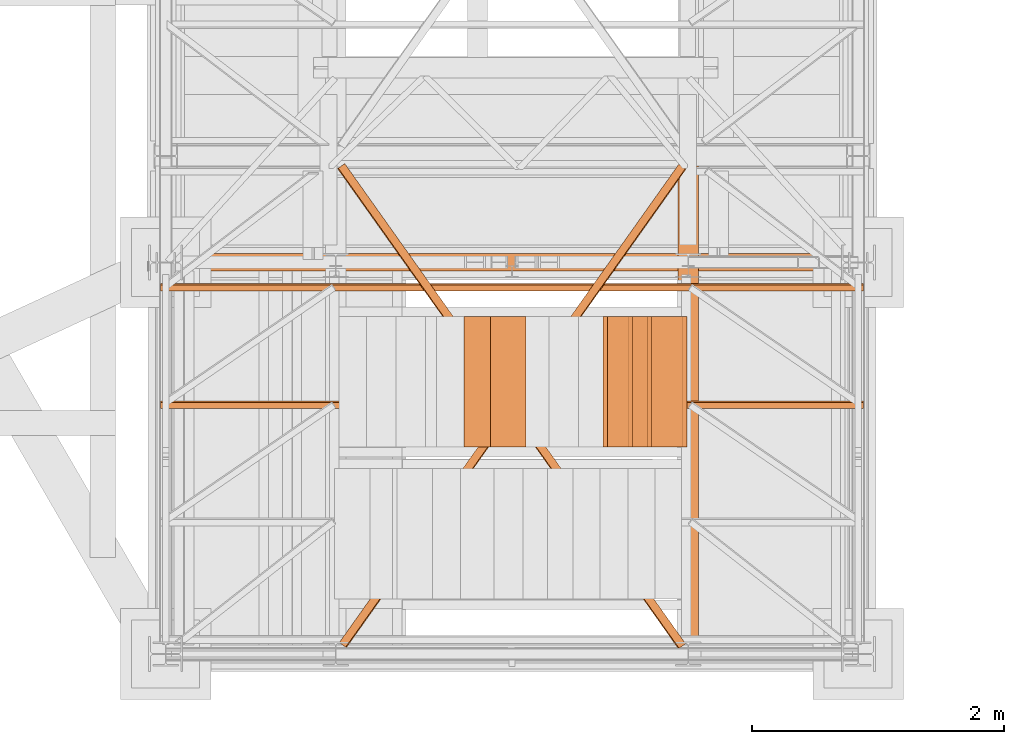
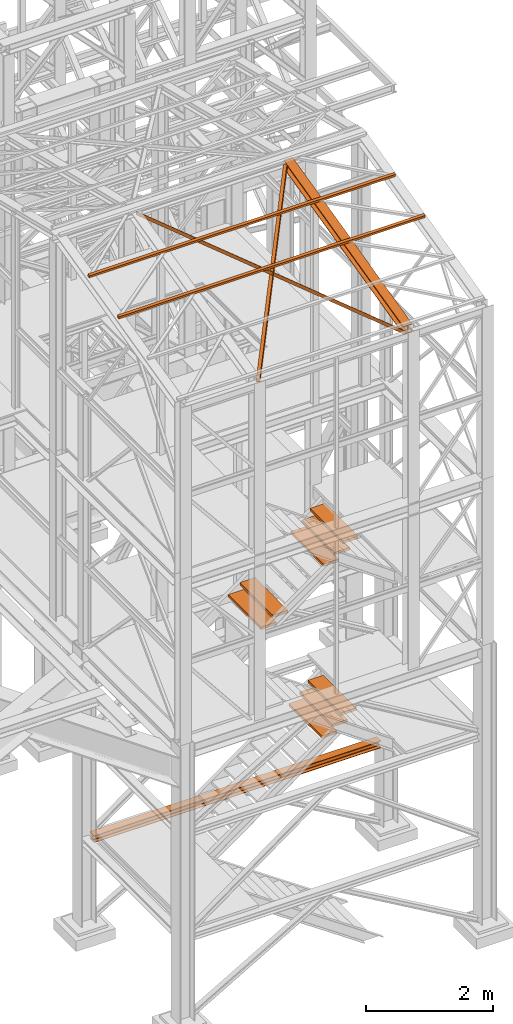
# One storey, part 53 of 208: 14 proxies.
"""IFC2X3 building model written with IfcOpenShell, lengths in millimetres."""

from ifc_helpers import new_model, entity, si_unit, converted_unit, frame, origin, origin_with_axes, place, context, subcontext, project, spatial, faceted_brep, element, save


model = new_model("IFC2X3")

# Units and contexts
model_context = context("Model", 3, precision=1e-05, world=origin())
plan_context = context("Plan", 3, precision=1e-05, world=origin())
body_context = subcontext(model_context, "Body", "Model", "MODEL_VIEW")
ifc_project = project(units=[si_unit("LENGTHUNIT", "METRE", prefix="MILLI"), converted_unit("PLANEANGLEUNIT", "DEGREE", entity("IfcPlaneAngleMeasure", 0.0174532925199433), si_unit("PLANEANGLEUNIT", "RADIAN"), dimensions=[0, 0, 0, 0, 0, 0, 0]), si_unit("AREAUNIT", "SQUARE_METRE"), si_unit("VOLUMEUNIT", "CUBIC_METRE")], contexts=[model_context, plan_context])

# Building, storey
building_placement = place(None, origin())
building = spatial("IfcBuilding", under=ifc_project, at=building_placement, CompositionType="COMPLEX")
storey_placement = place(building_placement, origin_with_axes())
storey = spatial("IfcBuildingStorey", under=building, at=storey_placement, Name="Geschoss", CompositionType="ELEMENT")

# Proxies
proxy_1_placement = place(storey_placement, frame((1333.254973893081, -22132.57439061591, 1433.489998909946), z_axis=(0.0, 0.0, 1.0), x_axis=(1.0, 0.0, 0.0)))
element("IfcBuildingElementProxy", 1, at=proxy_1_placement, inside=storey, context=body_context, shape_type="Brep", body=[
    faceted_brep([(0.01000000000021828, 0.01000000000567525, 8.510002324581137), (0.01000000000021828, 0.01000000000567525, 0.009999999999990905), (0.01000000000021828, 140.0100005960521, 0.009999999999990905), (0.01000000000021828, 140.0100005960521, 8.510002324581137), (0.01000000000021828, 84.76000038743587, 8.510002324581137), (0.01000000000021828, 78.54945996612878, 9.753034839630118), (0.01000000000021828, 74.00303279817672, 14.2994648015499), (0.01000000000021828, 72.76000051595838, 20.51000429153442), (0.01000000000021828, 72.76000051595838, 112.5100007450581), (0.01000000000021828, 74.00303279817672, 118.7205402350426), (0.01000000000021828, 78.54945996612878, 123.2669664716721), (0.01000000000021828, 84.76000038743587, 124.509998986721), (0.01000000000021828, 140.0100005960521, 124.509998986721), (0.01000000000021828, 140.0100005960521, 133.0100013113022), (0.01000000000021828, 0.01000000000567525, 133.0100013113022), (0.01000000000021828, 0.01000000000567525, 124.509998986721), (0.01000000000021828, 55.26000020862193, 124.509998986721), (0.01000000000021828, 61.47054062992902, 123.2669664716721), (0.01000000000021828, 66.01696779788108, 118.7205402350426), (0.01000000000021828, 67.26000008009942, 112.5100007450581), (0.01000000000021828, 67.26000008009942, 20.51000429153442), (0.01000000000021828, 66.01696779788108, 14.2994648015499), (0.01000000000021828, 61.47054062992902, 9.753034839630118), (0.01000000000021828, 55.26000020862193, 8.510002324581137), (0.01000000000021828, 0.01000000000567525, 0.009999999999990905), (0.01000000000021828, 0.01000000000567525, 8.510002324581137), (5230.009989271167, 0.01000000000203727, 8.510002324581137), (5230.009989271167, 0.01000000000203727, 0.009999999999990905), (0.01000000000021828, 140.0100005960521, 0.009999999999990905), (0.01000000000021828, 0.01000000000567525, 0.009999999999990905), (5230.009989271167, 0.01000000000203727, 0.009999999999990905), (5230.009989271167, 140.0100005960485, 0.009999999999990905), (0.01000000000021828, 140.0100005960521, 8.510002324581137), (0.01000000000021828, 140.0100005960521, 0.009999999999990905), (5230.009989271167, 140.0100005960485, 0.009999999999990905), (5230.009989271167, 140.0100005960485, 8.510002324581137), (0.01000000000021828, 84.76000038743587, 8.510002324581137), (0.01000000000021828, 140.0100005960521, 8.510002324581137), (5230.009989271167, 140.0100005960485, 8.510002324581137), (5230.009989271167, 84.76000038743223, 8.510002324581137), (0.01000000000021828, 78.54945996612878, 9.753034839630118), (0.01000000000021828, 84.76000038743587, 8.510002324581137), (5230.009989271167, 84.76000038743223, 8.510002324581137), (5230.009989271167, 78.54945996612514, 9.753034839630118), (0.01000000000021828, 74.00303279817672, 14.2994648015499), (0.01000000000021828, 78.54945996612878, 9.753034839630118), (5230.009989271167, 78.54945996612514, 9.753034839630118), (5230.009989271167, 74.00303279817308, 14.2994648015499), (0.01000000000021828, 72.76000051595838, 20.51000429153442), (0.01000000000021828, 74.00303279817672, 14.2994648015499), (5230.009989271167, 74.00303279817308, 14.2994648015499), (5230.009989271167, 72.76000051595474, 20.51000429153442), (0.01000000000021828, 72.76000051595838, 112.5100007450581), (0.01000000000021828, 72.76000051595838, 20.51000429153442), (5230.009989271167, 72.76000051595474, 20.51000429153442), (5230.009989271167, 72.76000051595474, 112.5100007450581), (0.01000000000021828, 74.00303279817672, 118.7205402350426), (0.01000000000021828, 72.76000051595838, 112.5100007450581), (5230.009989271167, 72.76000051595474, 112.5100007450581), (5230.009989271167, 74.00303279817308, 118.7205402350426), (0.01000000000021828, 78.54945996612878, 123.2669664716721), (0.01000000000021828, 74.00303279817672, 118.7205402350426), (5230.009989271167, 74.00303279817308, 118.7205402350426), (5230.009989271167, 78.54945996612514, 123.2669664716721), (0.01000000000021828, 84.76000038743587, 124.509998986721), (0.01000000000021828, 78.54945996612878, 123.2669664716721), (5230.009989271167, 78.54945996612514, 123.2669664716721), (5230.009989271167, 84.76000038743223, 124.509998986721), (0.01000000000021828, 140.0100005960521, 124.509998986721), (0.01000000000021828, 84.76000038743587, 124.509998986721), (5230.009989271167, 84.76000038743223, 124.509998986721), (5230.009989271167, 140.0100005960485, 124.509998986721), (0.01000000000021828, 140.0100005960521, 133.0100013113022), (0.01000000000021828, 140.0100005960521, 124.509998986721), (5230.009989271167, 140.0100005960485, 124.509998986721), (5230.009989271167, 140.0100005960485, 133.0100013113022), (0.01000000000021828, 0.01000000000567525, 133.0100013113022), (0.01000000000021828, 140.0100005960521, 133.0100013113022), (5230.009989271167, 140.0100005960485, 133.0100013113022), (5230.009989271167, 0.01000000000203727, 133.0100013113022), (0.01000000000021828, 0.01000000000567525, 124.509998986721), (0.01000000000021828, 0.01000000000567525, 133.0100013113022), (5230.009989271167, 0.01000000000203727, 133.0100013113022), (5230.009989271167, 0.01000000000203727, 124.509998986721), (0.01000000000021828, 55.26000020862193, 124.509998986721), (0.01000000000021828, 0.01000000000567525, 124.509998986721), (5230.009989271167, 0.01000000000203727, 124.509998986721), (5230.009989271167, 55.26000020861829, 124.509998986721), (0.01000000000021828, 61.47054062992902, 123.2669664716721), (0.01000000000021828, 55.26000020862193, 124.509998986721), (5230.009989271167, 55.26000020861829, 124.509998986721), (5230.009989271167, 61.47054062992538, 123.2669664716721), (0.01000000000021828, 66.01696779788108, 118.7205402350426), (0.01000000000021828, 61.47054062992902, 123.2669664716721), (5230.009989271167, 61.47054062992538, 123.2669664716721), (5230.009989271167, 66.01696779787744, 118.7205402350426), (0.01000000000021828, 67.26000008009942, 112.5100007450581), (0.01000000000021828, 66.01696779788108, 118.7205402350426), (5230.009989271167, 66.01696779787744, 118.7205402350426), (5230.009989271167, 67.26000008009578, 112.5100007450581), (0.01000000000021828, 67.26000008009942, 20.51000429153442), (0.01000000000021828, 67.26000008009942, 112.5100007450581), (5230.009989271167, 67.26000008009578, 112.5100007450581), (5230.009989271167, 67.26000008009578, 20.51000429153442), (0.01000000000021828, 66.01696779788108, 14.2994648015499), (0.01000000000021828, 67.26000008009942, 20.51000429153442), (5230.009989271167, 67.26000008009578, 20.51000429153442), (5230.009989271167, 66.01696779787744, 14.2994648015499), (0.01000000000021828, 61.47054062992902, 9.753034839630118), (0.01000000000021828, 66.01696779788108, 14.2994648015499), (5230.009989271167, 66.01696779787744, 14.2994648015499), (5230.009989271167, 61.47054062992538, 9.753034839630118), (0.01000000000021828, 55.26000020862193, 8.510002324581137), (0.01000000000021828, 61.47054062992902, 9.753034839630118), (5230.009989271167, 61.47054062992538, 9.753034839630118), (5230.009989271167, 55.26000020861829, 8.510002324581137), (0.01000000000021828, 0.01000000000567525, 8.510002324581137), (0.01000000000021828, 55.26000020862193, 8.510002324581137), (5230.009989271167, 55.26000020861829, 8.510002324581137), (5230.009989271167, 0.01000000000203727, 8.510002324581137), (5230.009989271167, 0.01000000000203727, 8.510002324581137), (5230.009989271167, 55.26000020861829, 8.510002324581137), (5230.009989271167, 61.47054062992538, 9.753034839630118), (5230.009989271167, 66.01696779787744, 14.2994648015499), (5230.009989271167, 67.26000008009578, 20.51000429153442), (5230.009989271167, 67.26000008009578, 112.5100007450581), (5230.009989271167, 66.01696779787744, 118.7205402350426), (5230.009989271167, 61.47054062992538, 123.2669664716721), (5230.009989271167, 55.26000020861829, 124.509998986721), (5230.009989271167, 0.01000000000203727, 124.509998986721), (5230.009989271167, 0.01000000000203727, 133.0100013113022), (5230.009989271167, 140.0100005960485, 133.0100013113022), (5230.009989271167, 140.0100005960485, 124.509998986721), (5230.009989271167, 84.76000038743223, 124.509998986721), (5230.009989271167, 78.54945996612514, 123.2669664716721), (5230.009989271167, 74.00303279817308, 118.7205402350426), (5230.009989271167, 72.76000051595474, 112.5100007450581), (5230.009989271167, 72.76000051595474, 20.51000429153442), (5230.009989271167, 74.00303279817308, 14.2994648015499), (5230.009989271167, 78.54945996612514, 9.753034839630118), (5230.009989271167, 84.76000038743223, 8.510002324581137), (5230.009989271167, 140.0100005960485, 8.510002324581137), (5230.009989271167, 140.0100005960485, 0.009999999999990905), (5230.009989271167, 0.01000000000203727, 0.009999999999990905)], [[[0, 1, 2, 3, 4, 5, 6, 7, 8, 9, 10, 11, 12, 13, 14, 15, 16, 17, 18, 19, 20, 21, 22, 23]], [[24, 25, 26, 27]], [[28, 29, 30, 31]], [[32, 33, 34, 35]], [[36, 37, 38, 39]], [[40, 41, 42, 43]], [[44, 45, 46, 47]], [[48, 49, 50, 51]], [[52, 53, 54, 55]], [[56, 57, 58, 59]], [[60, 61, 62, 63]], [[64, 65, 66, 67]], [[68, 69, 70, 71]], [[72, 73, 74, 75]], [[76, 77, 78, 79]], [[80, 81, 82, 83]], [[84, 85, 86, 87]], [[88, 89, 90, 91]], [[92, 93, 94, 95]], [[96, 97, 98, 99]], [[100, 101, 102, 103]], [[104, 105, 106, 107]], [[108, 109, 110, 111]], [[112, 113, 114, 115]], [[116, 117, 118, 119]], [[120, 121, 122, 123, 124, 125, 126, 127, 128, 129, 130, 131, 132, 133, 134, 135, 136, 137, 138, 139, 140, 141, 142, 143]]], orient=[[False], [False], [False], [False], [False], [False], [False], [False], [False], [False], [False], [False], [False], [False], [False], [False], [False], [False], [False], [False], [False], [False], [False], [False], [False], [False]]),
])
for number, where, z_axis, x_axis in (
    (2, (5022.476720343071, -23530.42800187884, 3443.990001490116), (0.0, 0.0, 1.0), (1.0, 0.0, 0.0)),
    (3, (4868.598750456611, -23530.42800187884, 3273.990001490115), (0.0, 0.0, 1.0), (1.0, 0.0, 0.0)),
    (4, (4671.437715496153, -23530.42800187884, 3121.502140765801), (0.0, 0.0, 1.0), (1.0, 0.0, 0.0)),
    (5, (5057.476720343067, -23530.42800187884, 6743.049952225937), (0.0, 0.0, 1.0), (1.0, 0.0, 0.0)),
    (6, (4903.598750456609, -23530.42800187884, 6573.049952225936), (0.0, 0.0, 1.0), (1.0, 0.0, 0.0)),
    (7, (4706.437715496153, -23530.42800187884, 6420.562091501623), (0.0, 0.0, 1.0), (1.0, 0.0, 0.0)),
):
    element("IfcBuildingElementProxy", number, at=place(storey_placement, frame(where, z_axis=z_axis, x_axis=x_axis)), inside=storey, context=body_context, shape_type="Brep", body=[
        faceted_brep([(0.009999999999308784, 0.00999999999839929, 0.01000000000021828), (280.2746556316179, 0.00999999999839929, 0.01000000000021828), (280.2746556316179, 1037.717170711916, 0.01000000000021828), (0.009999999999308784, 1037.717170711916, 0.01000000000021828), (280.2746556316179, 0.00999999999839929, 50.01000000000022), (0.009999999999308784, 0.00999999999839929, 50.01000000000022), (0.009999999999308784, 1037.717170711916, 50.01000000000022), (280.2746556316179, 1037.717170711916, 50.01000000000022), (280.2746556316179, 0.00999999999839929, 0.01000000000021828), (0.009999999999308784, 0.00999999999839929, 0.01000000000021828), (0.009999999999308784, 0.00999999999839929, 50.01000000000022), (280.2746556316179, 0.00999999999839929, 50.01000000000022), (280.2746556316179, 1037.717170711916, 0.01000000000021828), (280.2746556316179, 0.00999999999839929, 0.01000000000021828), (280.2746556316179, 0.00999999999839929, 50.01000000000022), (280.2746556316179, 1037.717170711916, 50.01000000000022), (0.009999999999308784, 1037.717170711916, 0.01000000000021828), (280.2746556316179, 1037.717170711916, 0.01000000000021828), (280.2746556316179, 1037.717170711916, 50.01000000000022), (0.009999999999308784, 1037.717170711916, 50.01000000000022), (0.009999999999308784, 0.00999999999839929, 0.01000000000021828), (0.009999999999308784, 1037.717170711916, 0.01000000000021828), (0.009999999999308784, 1037.717170711916, 50.01000000000022), (0.009999999999308784, 0.00999999999839929, 50.01000000000022)], [[[0, 1, 2, 3]], [[4, 5, 6, 7]], [[8, 9, 10, 11]], [[12, 13, 14, 15]], [[16, 17, 18, 19]], [[20, 21, 22, 23]]], orient=[[False], [False], [False], [False], [False], [False]]),
    ])
for number, where, z_axis, x_axis in (
    (8, (3565.974818265505, -23530.42800187884, 5605.165709983303), (0.0, 0.0, 1.0), (1.0, 0.0, 0.0)),
    (9, (3778.68549890098, -23530.42800187884, 5760.656955432321), (0.0, 0.0, 1.0), (1.0, 0.0, 0.0)),
):
    element("IfcBuildingElementProxy", number, at=place(storey_placement, frame(where, z_axis=z_axis, x_axis=x_axis)), inside=storey, context=body_context, shape_type="Brep", body=[
        faceted_brep([(0.01000000000021828, 0.00999999999839929, 0.01000000000021828), (280.2746556316183, 0.00999999999839929, 0.01000000000021828), (280.2746556316183, 1037.717170711916, 0.01000000000021828), (0.01000000000021828, 1037.717170711916, 0.01000000000021828), (280.2746556316183, 0.00999999999839929, 50.01000000000022), (0.01000000000021828, 0.00999999999839929, 50.01000000000022), (0.01000000000021828, 1037.717170711916, 50.01000000000022), (280.2746556316183, 1037.717170711916, 50.01000000000022), (280.2746556316183, 0.00999999999839929, 0.01000000000021828), (0.01000000000021828, 0.00999999999839929, 0.01000000000021828), (0.01000000000021828, 0.00999999999839929, 50.01000000000022), (280.2746556316183, 0.00999999999839929, 50.01000000000022), (280.2746556316183, 1037.717170711916, 0.01000000000021828), (280.2746556316183, 0.00999999999839929, 0.01000000000021828), (280.2746556316183, 0.00999999999839929, 50.01000000000022), (280.2746556316183, 1037.717170711916, 50.01000000000022), (0.01000000000021828, 1037.717170711916, 0.01000000000021828), (280.2746556316183, 1037.717170711916, 0.01000000000021828), (280.2746556316183, 1037.717170711916, 50.01000000000022), (0.01000000000021828, 1037.717170711916, 50.01000000000022), (0.01000000000021828, 0.00999999999839929, 0.01000000000021828), (0.01000000000021828, 1037.717170711916, 0.01000000000021828), (0.01000000000021828, 1037.717170711916, 50.01000000000022), (0.01000000000021828, 0.00999999999839929, 50.01000000000022)], [[[0, 1, 2, 3]], [[4, 5, 6, 7]], [[8, 9, 10, 11]], [[12, 13, 14, 15]], [[16, 17, 18, 19]], [[20, 21, 22, 23]]], orient=[[False], [False], [False], [False], [False], [False]]),
    ])
for number, where, z_axis, x_axis in (
    (10, (1157.254971121462, -22289.5100179109, 12464.98408158565), (0.0, 0.0, 1.0), (1.0, 0.0, 0.0)),
    (11, (1157.254971121462, -23222.63202388408, 12238.48670466169), (0.0, 0.0, 1.0), (1.0, 0.0, 0.0)),
):
    element("IfcBuildingElementProxy", number, at=place(storey_placement, frame(where, z_axis=z_axis, x_axis=x_axis)), inside=storey, context=body_context, shape_type="Brep", body=[
        faceted_brep([(5582.010002264974, 48.59909357395372, 60.39315927079588), (5582.010002264974, 60.39315927079224, 11.80406569683873), (5582.010002264974, 11.80406569683692, 0.01000000000021828), (5582.010002264974, 0.00999999999839929, 48.59909357395736), (0.01000000000021828, 0.00999999999839929, 48.59909357395736), (0.01000000000021828, 11.80406569683692, 0.01000000000021828), (0.01000000000021828, 60.39315927079224, 11.80406569683873), (0.01000000000021828, 48.59909357395372, 60.39315927079588), (5582.010002264974, 0.00999999999839929, 48.59909357395736), (0.01000000000021828, 0.00999999999839929, 48.59909357395736), (0.01000000000021828, 48.59909357395372, 60.39315927079588), (5582.010002264974, 48.59909357395372, 60.39315927079588), (5582.010002264974, 11.80406569683692, 0.01000000000021828), (0.01000000000021828, 11.80406569683692, 0.01000000000021828), (0.01000000000021828, 0.00999999999839929, 48.59909357395736), (5582.010002264974, 0.00999999999839929, 48.59909357395736), (5582.010002264974, 60.39315927079224, 11.80406569683873), (0.01000000000021828, 60.39315927079224, 11.80406569683873), (0.01000000000021828, 11.80406569683692, 0.01000000000021828), (5582.010002264974, 11.80406569683692, 0.01000000000021828), (5582.010002264974, 48.59909357395372, 60.39315927079588), (0.01000000000021828, 48.59909357395372, 60.39315927079588), (0.01000000000021828, 60.39315927079224, 11.80406569683873), (5582.010002264974, 60.39315927079224, 11.80406569683873)], [[[0, 1, 2, 3]], [[4, 5, 6, 7]], [[8, 9, 10, 11]], [[12, 13, 14, 15]], [[16, 17, 18, 19]], [[20, 21, 22, 23]]], orient=[[False], [False], [False], [False], [False], [False]]),
    ])
proxy_2_placement = place(storey_placement, frame((2575.61545741755, -25122.52386708432, 11664.17632924608), z_axis=(0.0, 0.0, 1.0), x_axis=(1.0, 0.0, 0.0)))
element("IfcBuildingElementProxy", 12, at=proxy_2_placement, inside=storey, context=body_context, shape_type="Brep", body=[
    faceted_brep([(2749.239290258735, 3804.073664817119, 950.2007534895147), (2749.240122121805, 3804.073086495988, 1014.47744829847), (51.74111174156951, 4.005938173664617, 71.5525025697425), (51.74027987850059, 4.006516494795505, 7.275807760785028), (2749.240122121805, 3804.073086495988, 1014.47744829847), (2754.98792072728, 3800.077148322322, 1014.491220829807), (57.48891034704411, 0.00999999999839929, 71.56627510107865), (51.74111174156951, 4.005938173664617, 71.5525025697425), (2754.98792072728, 3800.077148322322, 1014.491220829807), (2754.986996434981, 3800.077790901356, 943.0726710420768), (57.48798605474622, 0.01064257903271937, 0.1477253133507475), (57.48891034704411, 0.00999999999839929, 71.56627510107865), (2754.986996434981, 3800.077790901356, 943.0726710420768), (2697.509010380237, 3840.037172638015, 942.934945728728), (0.01000000000021828, 39.9700243156949, 0.01000000000021828), (57.48798605474622, 0.01064257903271937, 0.1477253133507475), (2697.509010380237, 3840.037172638015, 942.934945728728), (2697.509102809469, 3840.037108380118, 950.0768007075021), (0.01009242922918929, 39.96996005779147, 7.151854978770643), (0.01000000000021828, 39.9700243156949, 0.01000000000021828), (2697.509102809469, 3840.037108380118, 950.0768007075021), (2749.239290258735, 3804.073664817119, 950.2007534895147), (51.74027987850059, 4.006516494795505, 7.275807760785028), (0.01009242922918929, 39.96996005779147, 7.151854978770643), (2749.240122121805, 3804.073086495988, 1014.47744829847), (2749.239290258735, 3804.073664817119, 950.2007534895147), (2697.509102809469, 3840.037108380118, 950.0768007075021), (2697.509010380237, 3840.037172638015, 942.934945728728), (2754.986996434981, 3800.077790901356, 943.0726710420768), (2754.98792072728, 3800.077148322322, 1014.491220829807), (51.74027987850059, 4.006516494795505, 7.275807760785028), (51.74111174156951, 4.005938173664617, 71.5525025697425), (57.48891034704411, 0.00999999999839929, 71.56627510107865), (57.48798605474622, 0.01064257903271937, 0.1477253133507475), (0.01000000000021828, 39.9700243156949, 0.01000000000021828), (0.01009242922918929, 39.96996005779147, 7.151854978770643)], [[[0, 1, 2, 3]], [[4, 5, 6, 7]], [[8, 9, 10, 11]], [[12, 13, 14, 15]], [[16, 17, 18, 19]], [[20, 21, 22, 23]], [[24, 25, 26, 27, 28, 29]], [[30, 31, 32, 33, 34, 35]]], orient=[[False], [False], [False], [False], [False], [False], [False], [False]]),
])
proxy_3_placement = place(storey_placement, frame((2562.87849289545, -25131.35416242644, 11662.12296240696), z_axis=(0.0, 0.0, 1.0), x_axis=(1.0, 0.0, 0.0)))
element("IfcBuildingElementProxy", 13, at=proxy_3_placement, inside=storey, context=body_context, shape_type="Brep", body=[
    faceted_brep([(5.7182461291859, 3817.238937434824, 1017.606612844891), (5.71907226793337, 3817.239523820019, 953.3299200369001), (2712.524383413973, 4.062243602762464, 7.151908000914773), (2712.523557275225, 4.061657217567699, 71.42860080890387), (0.01000000000021828, 3813.187280217258, 1017.606559600419), (5.7182461291859, 3817.238937434824, 1017.606612844891), (2712.523557275225, 4.061657217567699, 71.42860080890387), (2706.815311146041, 0.00999999999839929, 71.42854756443194), (0.01091793194336788, 3813.187931756362, 946.1880120359856), (0.01000000000021828, 3813.187280217258, 1017.606559600419), (2706.815311146041, 0.00999999999839929, 71.42854756443194), (2706.816229077984, 0.0106515391053108, 0.01000000000021828), (57.09337922378745, 3853.70450393204, 946.188544480714), (0.01091793194336788, 3813.187931756362, 946.1880120359856), (2706.816229077984, 0.0106515391053108, 0.01000000000021828), (2763.898690369828, 40.52722371478376, 0.01053244472677761), (57.0932874305945, 3853.704438778128, 953.3303992371548), (57.09337922378745, 3853.70450393204, 946.188544480714), (2763.898690369828, 40.52722371478376, 0.01053244472677761), (2763.898598576629, 40.52715856087889, 7.152387201171223), (5.71907226793337, 3817.239523820019, 953.3299200369001), (57.0932874305945, 3853.704438778128, 953.3303992371548), (2763.898598576629, 40.52715856087889, 7.152387201171223), (2712.524383413973, 4.062243602762464, 7.151908000914773), (2712.523557275225, 4.061657217567699, 71.42860080890387), (2712.524383413973, 4.062243602762464, 7.151908000914773), (2763.898598576629, 40.52715856087889, 7.152387201171223), (2763.898690369828, 40.52722371478376, 0.01053244472677761), (2706.816229077984, 0.0106515391053108, 0.01000000000021828), (2706.815311146041, 0.00999999999839929, 71.42854756443194), (5.71907226793337, 3817.239523820019, 953.3299200369001), (5.7182461291859, 3817.238937434824, 1017.606612844891), (0.01000000000021828, 3813.187280217258, 1017.606559600419), (0.01091793194336788, 3813.187931756362, 946.1880120359856), (57.09337922378745, 3853.70450393204, 946.188544480714), (57.0932874305945, 3853.704438778128, 953.3303992371548)], [[[0, 1, 2, 3]], [[4, 5, 6, 7]], [[8, 9, 10, 11]], [[12, 13, 14, 15]], [[16, 17, 18, 19]], [[20, 21, 22, 23]], [[24, 25, 26, 27, 28, 29]], [[30, 31, 32, 33, 34, 35]]], orient=[[False], [False], [False], [False], [False], [False], [False], [False]]),
])
proxy_4_placement = place(storey_placement, frame((5268.254966591512, -25077.57437538435, 11628.70515179705), z_axis=(0.0, 0.0, 1.0), x_axis=(1.0, 0.0, 0.0)))
element("IfcBuildingElementProxy", 14, at=proxy_4_placement, inside=storey, context=body_context, shape_type="Brep", body=[
    faceted_brep([(160.01001132489, 3780.009979404025, 1074.775244917653), (160.01001132488, 0.00999999999839929, 156.4315054631916), (0.01000000000021828, 0.00999999999839929, 156.4315054631916), (0.01000000000749424, 3780.009979404025, 1074.775244917653), (0.01000000000749424, 3780.009979404025, 1074.775244917653), (0.01000000000021828, 0.00999999999839929, 156.4315054631916), (0.01000000000021828, 0.00999999999839929, 147.1697029728093), (0.01000000000749424, 3780.009979404025, 1065.513442427271), (0.01000000000749424, 3780.009979404025, 1065.513442427271), (0.01000000000021828, 0.00999999999839929, 147.1697029728093), (62.01000457465671, 0.00999999999839929, 147.1697029728093), (62.01000457466307, 3780.009979404025, 1065.513442427271), (62.01000457466307, 3780.009979404025, 1065.513442427271), (62.01000457465671, 0.00999999999839929, 147.1697029728093), (69.77318079977886, 0.00999999999839929, 145.5707163655079), (69.77318079978886, 3780.009979404025, 1063.914455819968), (69.77318079978886, 3780.009979404025, 1063.914455819968), (69.77318079977886, 0.00999999999839929, 145.5707163655079), (75.45621545821086, 0.00999999999839929, 139.7223691397903), (75.45621545822178, 3780.009979404025, 1058.066108594254), (75.45621545822178, 3780.009979404025, 1058.066108594254), (75.45621545821086, 0.00999999999839929, 139.7223691397903), (77.0100056363608, 0.00999999999839929, 131.7333744340358), (77.0100056363708, 3780.009979404025, 1050.077113888498), (77.0100056363708, 3780.009979404025, 1050.077113888498), (77.0100056363608, 0.00999999999839929, 131.7333744340358), (77.0100056363608, 0.00999999999839929, 24.70813486281259), (77.0100056363708, 3780.009979404025, 943.0518743172743), (77.0100056363708, 3780.009979404025, 943.0518743172743), (77.0100056363608, 0.00999999999839929, 24.70813486281259), (75.45621545821086, 0.00999999999839929, 16.71913632339965), (75.45621545822087, 3780.009979404025, 935.0628757778613), (75.45621545822087, 3780.009979404025, 935.0628757778613), (75.45621545821086, 0.00999999999839929, 16.71913632339965), (69.77318079977886, 0.00999999999839929, 10.87078909768752), (69.77318079978886, 3780.009979404025, 929.2145285521474), (69.77318079978886, 3780.009979404025, 929.2145285521474), (69.77318079977886, 0.00999999999839929, 10.87078909768752), (62.01000457465307, 0.00999999999839929, 9.27180249038247), (62.01000457466307, 3780.009979404025, 927.6155419448442), (62.01000457466307, 3780.009979404025, 927.6155419448442), (62.01000457465307, 0.00999999999839929, 9.27180249038247), (0.01000000000021828, 0.00999999999839929, 9.27180249038247), (0.01000000000749424, 3780.009979404025, 927.6155419448423), (0.01000000000749424, 3780.009979404025, 927.6155419448423), (0.01000000000021828, 0.00999999999839929, 9.27180249038247), (0.01000000000021828, 0.00999999999839929, 0.01000000000021828), (0.01000000000658474, 3780.009979404025, 918.3537394544601), (0.01000000000658474, 3780.009979404025, 918.3537394544601), (0.01000000000021828, 0.00999999999839929, 0.01000000000021828), (160.0100113248827, 0.00999999999839929, 0.01000000000021828), (160.01001132489, 3780.009979404025, 918.3537394544619), (160.01001132489, 3780.009979404025, 918.3537394544619), (160.0100113248827, 0.00999999999839929, 0.01000000000021828), (160.0100113248836, 0.00999999999839929, 9.27180249038065), (160.01001132489, 3780.009979404025, 927.6155419448423), (160.01001132489, 3780.009979404025, 927.6155419448423), (160.0100113248836, 0.00999999999839929, 9.27180249038065), (98.0100067502226, 0.00999999999839929, 9.27180249038247), (98.0100067502326, 3780.009979404025, 927.6155419448423), (98.0100067502326, 3780.009979404025, 927.6155419448423), (98.0100067502226, 0.00999999999839929, 9.27180249038247), (90.24683052509681, 0.00999999999839929, 10.87078909768752), (90.24683052510682, 3780.009979404025, 929.2145285521474), (90.24683052510682, 3780.009979404025, 929.2145285521474), (90.24683052509681, 0.00999999999839929, 10.87078909768752), (84.5637958666648, 0.00999999999839929, 16.71913632339783), (84.56379586667481, 3780.009979404025, 935.0628757778613), (84.56379586667481, 3780.009979404025, 935.0628757778613), (84.5637958666648, 0.00999999999839929, 16.71913632339783), (83.01000568851487, 0.00999999999839929, 24.70813486281077), (83.01000568852487, 3780.009979404025, 943.0518743172743), (83.01000568852487, 3780.009979404025, 943.0518743172743), (83.01000568851487, 0.00999999999839929, 24.70813486281077), (83.01000568851487, 0.00999999999839929, 131.733374434034), (83.01000568852487, 3780.009979404025, 1050.077113888496), (83.01000568852487, 3780.009979404025, 1050.077113888496), (83.01000568851487, 0.00999999999839929, 131.733374434034), (84.5637958666648, 0.00999999999839929, 139.7223691397903), (84.56379586667572, 3780.009979404025, 1058.066108594254), (84.56379586667572, 3780.009979404025, 1058.066108594254), (84.5637958666648, 0.00999999999839929, 139.7223691397903), (90.24683052509681, 0.00999999999839929, 145.5707163655079), (90.24683052510773, 3780.009979404025, 1063.914455819968), (90.24683052510773, 3780.009979404025, 1063.914455819968), (90.24683052509681, 0.00999999999839929, 145.5707163655079), (98.0100067502226, 0.00999999999839929, 147.1697029728093), (98.0100067502326, 3780.009979404025, 1065.513442427271), (98.0100067502326, 3780.009979404025, 1065.513442427271), (98.0100067502226, 0.00999999999839929, 147.1697029728093), (160.0100113248827, 0.00999999999839929, 147.1697029728093), (160.01001132489, 3780.009979404025, 1065.513442427271), (160.01001132489, 3780.009979404025, 1065.513442427271), (160.0100113248827, 0.00999999999839929, 147.1697029728093), (160.01001132488, 0.00999999999839929, 156.4315054631916), (160.01001132489, 3780.009979404025, 1074.775244917653), (0.01000000000749424, 3780.009979404025, 1074.775244917653), (0.01000000000749424, 3780.009979404025, 1065.513442427271), (62.01000457466307, 3780.009979404025, 1065.513442427271), (69.77318079978886, 3780.009979404025, 1063.914455819968), (75.45621545822178, 3780.009979404025, 1058.066108594254), (77.0100056363708, 3780.009979404025, 1050.077113888498), (77.0100056363708, 3780.009979404025, 943.0518743172743), (75.45621545822087, 3780.009979404025, 935.0628757778613), (69.77318079978886, 3780.009979404025, 929.2145285521474), (62.01000457466307, 3780.009979404025, 927.6155419448442), (0.01000000000749424, 3780.009979404025, 927.6155419448423), (0.01000000000658474, 3780.009979404025, 918.3537394544601), (160.01001132489, 3780.009979404025, 918.3537394544619), (160.01001132489, 3780.009979404025, 927.6155419448423), (98.0100067502326, 3780.009979404025, 927.6155419448423), (90.24683052510682, 3780.009979404025, 929.2145285521474), (84.56379586667481, 3780.009979404025, 935.0628757778613), (83.01000568852487, 3780.009979404025, 943.0518743172743), (83.01000568852487, 3780.009979404025, 1050.077113888496), (84.56379586667572, 3780.009979404025, 1058.066108594254), (90.24683052510773, 3780.009979404025, 1063.914455819968), (98.0100067502326, 3780.009979404025, 1065.513442427271), (160.01001132489, 3780.009979404025, 1065.513442427271), (160.01001132489, 3780.009979404025, 1074.775244917653), (160.01001132488, 0.00999999999839929, 156.4315054631916), (160.0100113248827, 0.00999999999839929, 147.1697029728093), (98.0100067502226, 0.00999999999839929, 147.1697029728093), (90.24683052509681, 0.00999999999839929, 145.5707163655079), (84.5637958666648, 0.00999999999839929, 139.7223691397903), (83.01000568851487, 0.00999999999839929, 131.733374434034), (83.01000568851487, 0.00999999999839929, 24.70813486281077), (84.5637958666648, 0.00999999999839929, 16.71913632339783), (90.24683052509681, 0.00999999999839929, 10.87078909768752), (98.0100067502226, 0.00999999999839929, 9.27180249038247), (160.0100113248836, 0.00999999999839929, 9.27180249038065), (160.0100113248827, 0.00999999999839929, 0.01000000000021828), (0.01000000000021828, 0.00999999999839929, 0.01000000000021828), (0.01000000000021828, 0.00999999999839929, 9.27180249038247), (62.01000457465307, 0.00999999999839929, 9.27180249038247), (69.77318079977886, 0.00999999999839929, 10.87078909768752), (75.45621545821086, 0.00999999999839929, 16.71913632339965), (77.0100056363608, 0.00999999999839929, 24.70813486281259), (77.0100056363608, 0.00999999999839929, 131.7333744340358), (75.45621545821086, 0.00999999999839929, 139.7223691397903), (69.77318079977886, 0.00999999999839929, 145.5707163655079), (62.01000457465671, 0.00999999999839929, 147.1697029728093), (0.01000000000021828, 0.00999999999839929, 147.1697029728093), (0.01000000000021828, 0.00999999999839929, 156.4315054631916)], [[[0, 1, 2, 3]], [[4, 5, 6, 7]], [[8, 9, 10, 11]], [[12, 13, 14, 15]], [[16, 17, 18, 19]], [[20, 21, 22, 23]], [[24, 25, 26, 27]], [[28, 29, 30, 31]], [[32, 33, 34, 35]], [[36, 37, 38, 39]], [[40, 41, 42, 43]], [[44, 45, 46, 47]], [[48, 49, 50, 51]], [[52, 53, 54, 55]], [[56, 57, 58, 59]], [[60, 61, 62, 63]], [[64, 65, 66, 67]], [[68, 69, 70, 71]], [[72, 73, 74, 75]], [[76, 77, 78, 79]], [[80, 81, 82, 83]], [[84, 85, 86, 87]], [[88, 89, 90, 91]], [[92, 93, 94, 95]], [[96, 97, 98, 99, 100, 101, 102, 103, 104, 105, 106, 107, 108, 109, 110, 111, 112, 113, 114, 115, 116, 117, 118, 119]], [[120, 121, 122, 123, 124, 125, 126, 127, 128, 129, 130, 131, 132, 133, 134, 135, 136, 137, 138, 139, 140, 141, 142, 143]]], orient=[[False], [False], [False], [False], [False], [False], [False], [False], [False], [False], [False], [False], [False], [False], [False], [False], [False], [False], [False], [False], [False], [False], [False], [False], [False], [False]]),
])

save(model, "model.ifc")
